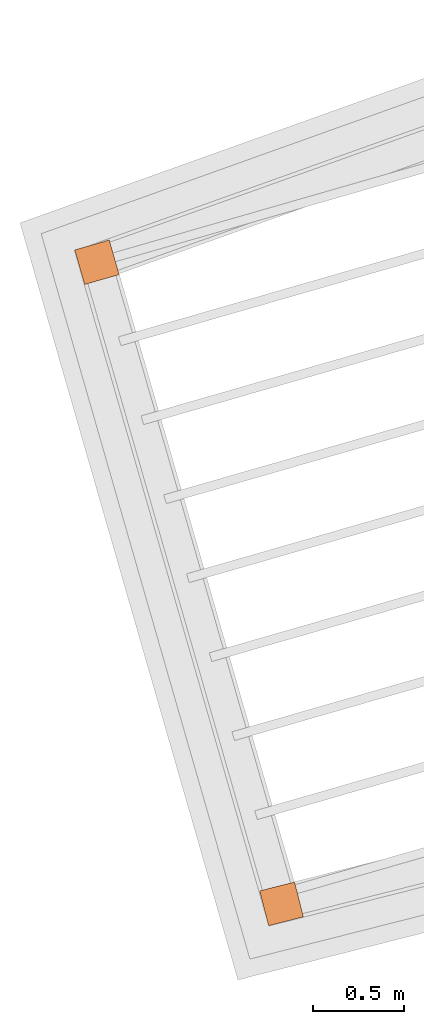
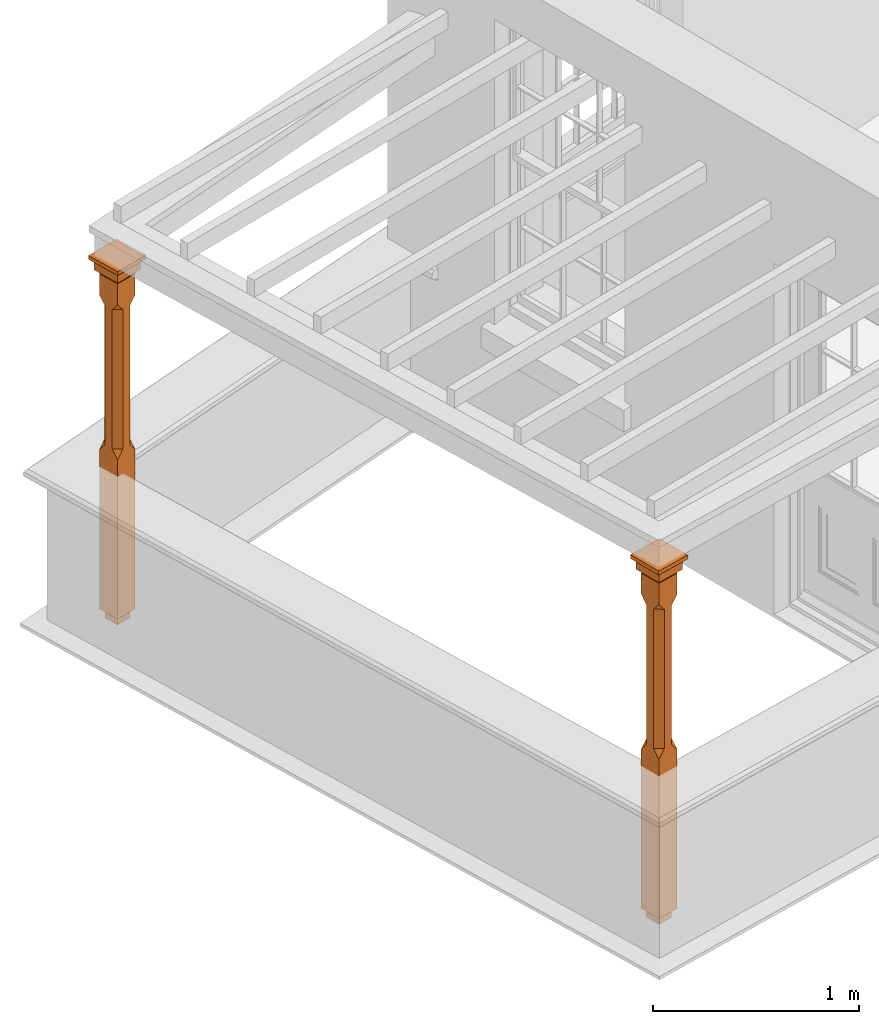
# One storey, part 11 of 11: 2 proxies.
"""IFC2X3 building model written with IfcOpenShell, lengths in metres."""

from ifc_helpers import new_model, si_unit, frame, origin, place, context, subcontext, project, spatial, faceted_brep, element, save


model = new_model("IFC2X3")

# Units and contexts
model_context = context("Model", 3, world=origin())
body_context = subcontext(model_context, "Body", "Model", "MODEL_VIEW")
ifc_project = project(units=[si_unit("PLANEANGLEUNIT", "RADIAN"), si_unit("MASSUNIT", "GRAM", prefix="KILO"), si_unit("FORCEUNIT", "NEWTON", prefix="KILO"), si_unit("LENGTHUNIT", "METRE")], contexts=[model_context])

# Site, building, storey
site_placement = place(None, origin())
site = spatial("IfcSite", under=ifc_project, at=site_placement, CompositionType="ELEMENT")
building_placement = place(None, origin())
building = spatial("IfcBuilding", under=site, at=building_placement, Name="Building plot-13", CompositionType="ELEMENT")
storey_placement = place(None, frame((0.0, 0.0, 6.7)))
storey = spatial("IfcBuildingStorey", under=building, at=storey_placement, Name="Floor 1", CompositionType="ELEMENT", Elevation=6.7)

# Proxies
proxy_1_placement = place(storey_placement, frame((63.4113078183222, 46.7329077993252, 0.0), z_axis=(0.0, 0.0, 1.0), x_axis=(0.276545964231412, -0.961000691814173, 0.0)))
element("IfcBuildingElementProxy", 1, at=proxy_1_placement, inside=storey, Name="pergola post", CompositionType="ELEMENT", context=body_context, shape_type="Brep", held_by="IfcProductRepresentation", body=[
    faceted_brep([(0.0246, -0.0615, 1.87), (0.0615, -0.0246, 1.87), (0.0615, -0.0615, 1.916667), (0.0615, -0.0246, 1.044444), (0.0246, -0.0615, 1.044444), (0.0615, 0.0246, 1.87), (0.0615, 0.0615, 1.916667), (-0.0246, -0.0615, 1.87), (-0.0615, -0.0615, 1.916667), (-0.0246, -0.0615, 1.044444), (0.0615, -0.0615, 0.997778), (0.0615, 0.0246, 1.044444), (0.0246, 0.0615, 1.87), (0.0615, 0.0615, 2.041111), (0.0615, -0.0615, 2.041111), (-0.0615, -0.0615, 2.041111), (-0.0615, -0.0246, 1.87), (-0.0615, -0.0246, 1.044444), (-0.0615, -0.0615, 0.997778), (0.0615, 0.0615, 0.997778), (0.0246, 0.0615, 1.044444), (-0.0246, 0.0615, 1.87), (-0.0615, 0.0615, 1.916667), (0.04305, 0.04305, 2.041111), (0.04305, -0.04305, 2.041111), (-0.0615, 0.0615, 2.041111), (-0.04305, -0.04305, 2.041111), (-0.0615, 0.0246, 1.87), (-0.0615, 0.0246, 1.044444), (0.0615, -0.0615, 0.053333), (-0.0615, -0.0615, 0.053333), (0.0615, 0.0615, 0.053333), (-0.0246, 0.0615, 1.044444), (-0.04305, 0.04305, 2.041111), (0.04305, 0.04305, 2.064444), (0.04305, -0.04305, 2.064444), (-0.04305, -0.04305, 2.064444), (-0.0615, 0.0615, 0.997778), (-0.0615, 0.0615, 0.053333), (-0.04305, -0.04305, 0.053333), (0.04305, -0.04305, 0.053333), (0.04305, 0.04305, 0.053333), (-0.04305, 0.04305, 2.064444), (0.07995, 0.07995, 2.064444), (0.07995, -0.07995, 2.064444), (-0.07995, -0.07995, 2.064444), (-0.04305, 0.04305, 0.053333), (-0.04305, -0.04305, 0.0), (0.04305, -0.04305, 0.0), (0.04305, 0.04305, 0.0), (-0.07995, 0.07995, 2.064444), (0.07995, 0.07995, 2.126667), (0.07995, -0.07995, 2.126667), (-0.07995, -0.07995, 2.126667), (-0.04305, 0.04305, 0.0), (-0.07995, 0.07995, 2.126667), (0.0984, 0.0984, 2.126667), (0.0984, -0.0984, 2.126667), (-0.0984, -0.0984, 2.126667), (-0.0984, 0.0984, 2.126667), (0.0984, 0.0984, 2.15), (0.0984, -0.0984, 2.15), (-0.0984, -0.0984, 2.15), (-0.0984, 0.0984, 2.15)], [[[0, 1, 2]], [[3, 1, 0, 4]], [[1, 5, 6, 2]], [[7, 0, 2, 8]], [[4, 0, 7, 9]], [[3, 4, 10]], [[1, 3, 11, 5]], [[5, 12, 6]], [[13, 14, 2, 6]], [[15, 8, 2, 14]], [[8, 16, 7]], [[9, 7, 16, 17]], [[9, 18, 10, 4]], [[3, 10, 19, 11]], [[20, 12, 5, 11]], [[21, 22, 6, 12]], [[14, 13, 23, 24]], [[13, 6, 22, 25]], [[25, 22, 8, 15]], [[26, 15, 14, 24]], [[16, 8, 22, 27]], [[27, 28, 17, 16]], [[17, 18, 9]], [[29, 10, 18, 30]], [[31, 19, 10, 29]], [[20, 11, 19]], [[12, 20, 32, 21]], [[21, 27, 22]], [[33, 23, 13, 25]], [[23, 34, 35, 24]], [[26, 33, 25, 15]], [[36, 26, 24, 35]], [[28, 27, 21, 32]], [[17, 28, 37, 18]], [[38, 30, 18, 37]], [[29, 30, 39, 40]], [[31, 38, 37, 19]], [[40, 41, 31, 29]], [[32, 20, 19, 37]], [[33, 42, 34, 23]], [[43, 44, 35, 34]], [[42, 33, 26, 36]], [[36, 35, 44, 45]], [[28, 32, 37]], [[46, 39, 30, 38]], [[39, 47, 48, 40]], [[46, 38, 31, 41]], [[49, 41, 40, 48]], [[43, 34, 42, 50]], [[43, 51, 52, 44]], [[45, 50, 42, 36]], [[53, 45, 44, 52]], [[46, 54, 47, 39]], [[54, 46, 41, 49]], [[50, 55, 51, 43]], [[56, 57, 52, 51]], [[55, 50, 45, 53]], [[53, 52, 57, 58]], [[56, 51, 55, 59]], [[56, 60, 61, 57]], [[58, 59, 55, 53]], [[62, 58, 57, 61]], [[59, 63, 60, 56]], [[63, 62, 61, 60]], [[58, 62, 63, 59]], [[47, 54, 49, 48]]]),
])
proxy_2_placement = place(storey_placement, frame((64.4222488743234, 43.2198749590139, 0.0), z_axis=(0.0, 0.0, 1.0), x_axis=(0.969309611759117, 0.245843195047963, 0.0)))
element("IfcBuildingElementProxy", 2, at=proxy_2_placement, inside=storey, Name="pergola post", CompositionType="ELEMENT", context=body_context, shape_type="Brep", held_by="IfcProductRepresentation", body=[
    faceted_brep([(0.0246, -0.0615, 1.87), (0.0615, -0.0246, 1.87), (0.0615, -0.0615, 1.916667), (0.0615, -0.0246, 1.044444), (0.0246, -0.0615, 1.044444), (0.0615, 0.0246, 1.87), (0.0615, 0.0615, 1.916667), (-0.0246, -0.0615, 1.87), (-0.0615, -0.0615, 1.916667), (-0.0246, -0.0615, 1.044444), (0.0615, -0.0615, 0.997778), (0.0615, 0.0246, 1.044444), (0.0246, 0.0615, 1.87), (0.0615, 0.0615, 2.041111), (0.0615, -0.0615, 2.041111), (-0.0615, -0.0615, 2.041111), (-0.0615, -0.0246, 1.87), (-0.0615, -0.0246, 1.044444), (-0.0615, -0.0615, 0.997778), (0.0615, 0.0615, 0.997778), (0.0246, 0.0615, 1.044444), (-0.0246, 0.0615, 1.87), (-0.0615, 0.0615, 1.916667), (0.04305, 0.04305, 2.041111), (0.04305, -0.04305, 2.041111), (-0.0615, 0.0615, 2.041111), (-0.04305, -0.04305, 2.041111), (-0.0615, 0.0246, 1.87), (-0.0615, 0.0246, 1.044444), (0.0615, -0.0615, 0.053333), (-0.0615, -0.0615, 0.053333), (0.0615, 0.0615, 0.053333), (-0.0246, 0.0615, 1.044444), (-0.04305, 0.04305, 2.041111), (0.04305, 0.04305, 2.064444), (0.04305, -0.04305, 2.064444), (-0.04305, -0.04305, 2.064444), (-0.0615, 0.0615, 0.997778), (-0.0615, 0.0615, 0.053333), (-0.04305, -0.04305, 0.053333), (0.04305, -0.04305, 0.053333), (0.04305, 0.04305, 0.053333), (-0.04305, 0.04305, 2.064444), (0.07995, 0.07995, 2.064444), (0.07995, -0.07995, 2.064444), (-0.07995, -0.07995, 2.064444), (-0.04305, 0.04305, 0.053333), (-0.04305, -0.04305, 0.0), (0.04305, -0.04305, 0.0), (0.04305, 0.04305, 0.0), (-0.07995, 0.07995, 2.064444), (0.07995, 0.07995, 2.126667), (0.07995, -0.07995, 2.126667), (-0.07995, -0.07995, 2.126667), (-0.04305, 0.04305, 0.0), (-0.07995, 0.07995, 2.126667), (0.0984, 0.0984, 2.126667), (0.0984, -0.0984, 2.126667), (-0.0984, -0.0984, 2.126667), (-0.0984, 0.0984, 2.126667), (0.0984, 0.0984, 2.15), (0.0984, -0.0984, 2.15), (-0.0984, -0.0984, 2.15), (-0.0984, 0.0984, 2.15)], [[[0, 1, 2]], [[3, 1, 0, 4]], [[1, 5, 6, 2]], [[7, 0, 2, 8]], [[4, 0, 7, 9]], [[3, 4, 10]], [[1, 3, 11, 5]], [[5, 12, 6]], [[13, 14, 2, 6]], [[15, 8, 2, 14]], [[8, 16, 7]], [[9, 7, 16, 17]], [[9, 18, 10, 4]], [[3, 10, 19, 11]], [[20, 12, 5, 11]], [[21, 22, 6, 12]], [[14, 13, 23, 24]], [[13, 6, 22, 25]], [[25, 22, 8, 15]], [[26, 15, 14, 24]], [[16, 8, 22, 27]], [[27, 28, 17, 16]], [[17, 18, 9]], [[29, 10, 18, 30]], [[31, 19, 10, 29]], [[20, 11, 19]], [[12, 20, 32, 21]], [[21, 27, 22]], [[33, 23, 13, 25]], [[23, 34, 35, 24]], [[26, 33, 25, 15]], [[36, 26, 24, 35]], [[28, 27, 21, 32]], [[17, 28, 37, 18]], [[38, 30, 18, 37]], [[29, 30, 39, 40]], [[31, 38, 37, 19]], [[40, 41, 31, 29]], [[32, 20, 19, 37]], [[33, 42, 34, 23]], [[43, 44, 35, 34]], [[42, 33, 26, 36]], [[36, 35, 44, 45]], [[28, 32, 37]], [[46, 39, 30, 38]], [[39, 47, 48, 40]], [[46, 38, 31, 41]], [[49, 41, 40, 48]], [[43, 34, 42, 50]], [[43, 51, 52, 44]], [[45, 50, 42, 36]], [[53, 45, 44, 52]], [[46, 54, 47, 39]], [[54, 46, 41, 49]], [[50, 55, 51, 43]], [[56, 57, 52, 51]], [[55, 50, 45, 53]], [[53, 52, 57, 58]], [[56, 51, 55, 59]], [[56, 60, 61, 57]], [[58, 59, 55, 53]], [[62, 58, 57, 61]], [[59, 63, 60, 56]], [[63, 62, 61, 60]], [[58, 62, 63, 59]], [[47, 54, 49, 48]]]),
])

save(model, "model.ifc")
